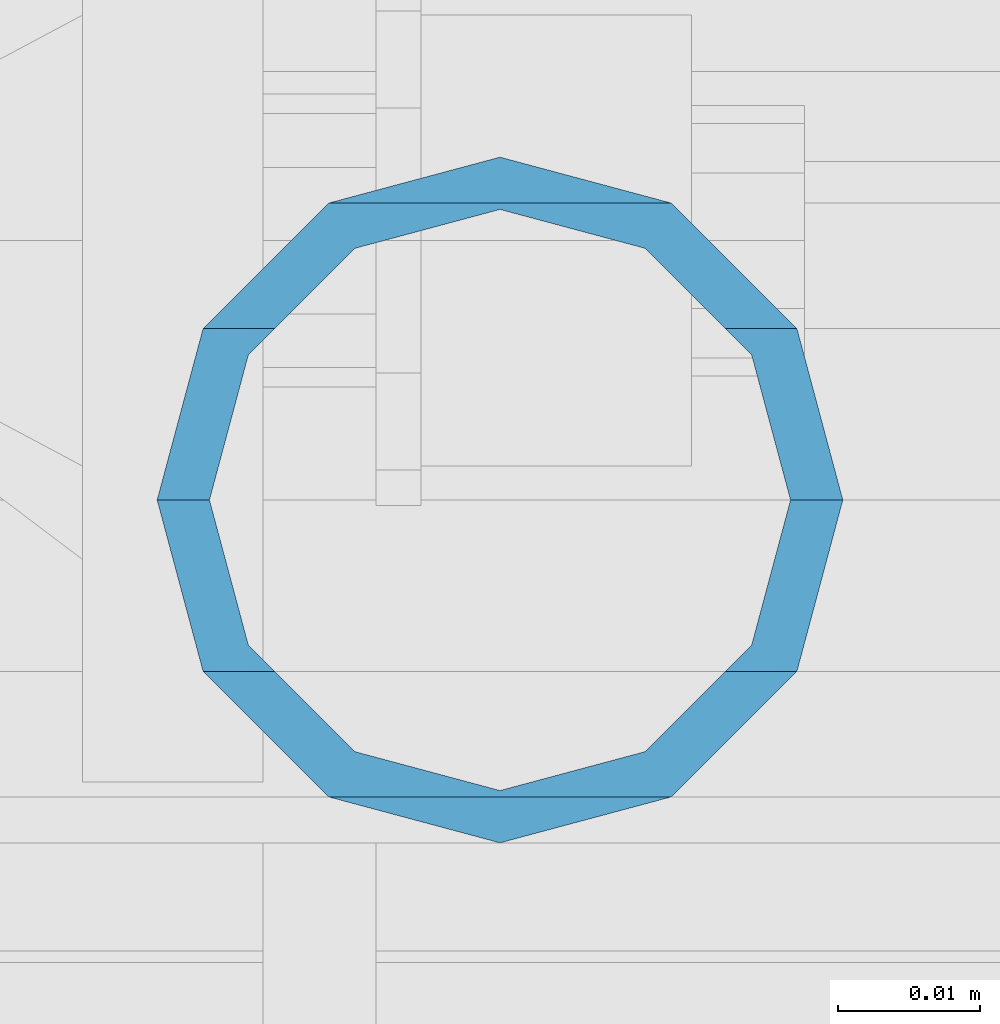
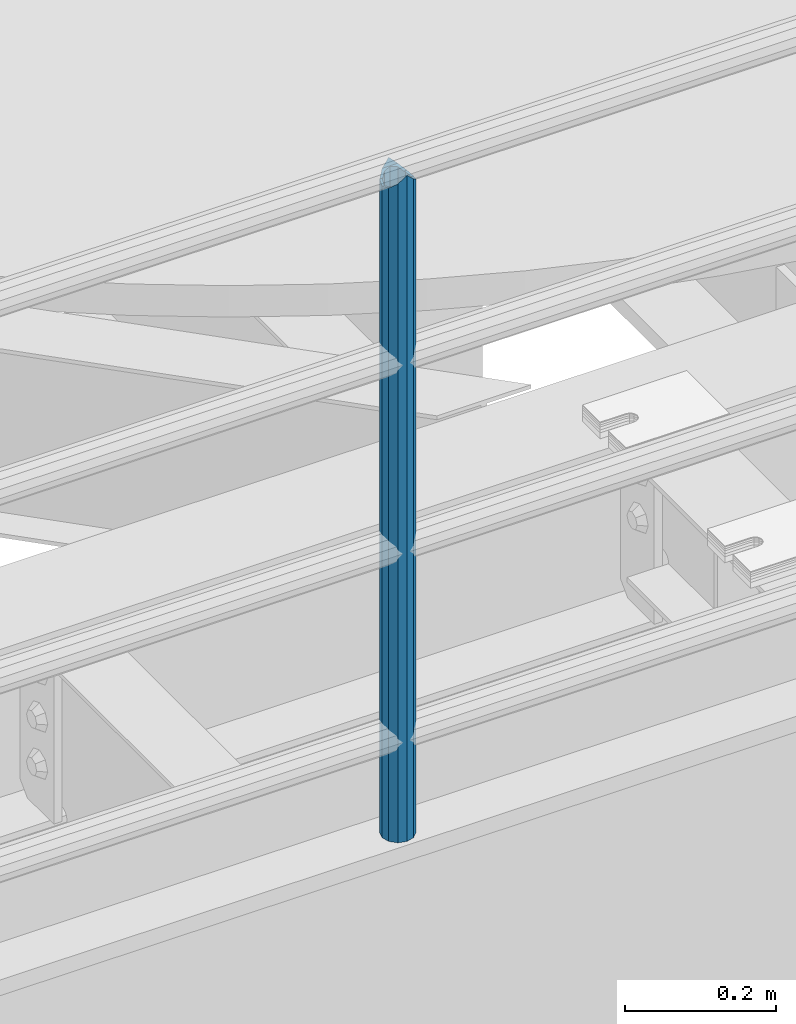
# One storey, part 613 of 1876: 1 column, 1 element without a shape of its own.
"""IFC2X3 building model written with IfcOpenShell, lengths in millimetres."""

from ifc_helpers import new_model, si_unit, frame, origin_with_axes, place, context, subcontext, project, spatial, faceted_brep, material, type_object, element, aggregate, save


model = new_model("IFC2X3")

# Units and contexts
model_context = context("Model", 3, precision=1e-05, world=origin_with_axes())
body_context = subcontext(model_context, "Body", "Model", "MODEL_VIEW")
ifc_project = project(units=[si_unit("LENGTHUNIT", "METRE", prefix="MILLI"), si_unit("AREAUNIT", "SQUARE_METRE"), si_unit("VOLUMEUNIT", "CUBIC_METRE"), si_unit("MASSUNIT", "GRAM", prefix="KILO"), si_unit("TIMEUNIT", "SECOND"), si_unit("PLANEANGLEUNIT", "RADIAN"), si_unit("SOLIDANGLEUNIT", "STERADIAN"), si_unit("THERMODYNAMICTEMPERATUREUNIT", "DEGREE_CELSIUS"), si_unit("LUMINOUSINTENSITYUNIT", "LUMEN")], contexts=[model_context])

# Site, building, storey
site_placement = place(None, origin_with_axes())
site = spatial("IfcSite", under=ifc_project, at=site_placement, CompositionType="ELEMENT")
building_placement = place(site_placement, origin_with_axes())
building = spatial("IfcBuilding", under=site, at=building_placement, Name="Undefined", CompositionType="ELEMENT")
storey_placement = place(building_placement, origin_with_axes())
storey = spatial("IfcBuildingStorey", under=building, at=storey_placement, Name="Undefined", CompositionType="ELEMENT", Elevation=0.0)

# Assembly, column
assembly_placement = place(storey_placement, origin_with_axes())
assembly = element("IfcElementAssembly", 1, at=assembly_placement, inside=storey, Name="RAIL", AssemblyPlace="NOTDEFINED", PredefinedType="RIGID_FRAME")
ifc_material = material()
column_type = type_object("IfcColumnType", Name="PIPE1-1/2SCH40", PredefinedType="NOTDEFINED")
column_placement = place(assembly_placement, frame((2870.19999998823, -4654.55000114554, 17983.2), z_axis=(0.0, 1.0, 0.0), x_axis=(0.0, 0.0, 1.0)))
column = element("IfcColumn", 2, at=column_placement, type_object=column_type, material=ifc_material, Name="POST", ObjectType="PIPE1-1/2SCH40", context=body_context, shape_type="Brep", body=[
    faceted_brep([(1076.325, 0.0, -24.1300000000001), (1064.26, 12.065, -20.8971929933186), (1064.26, -12.0650000000001, -20.8971929933186), (1054.93437856882, 17.7076214311801, 10.2235000000001), (1052.195, 20.4470000000001, 0.0), (1052.195, 24.13, 0.0), (1055.42780700668, 20.8971929933185, 12.0649999999996), (1055.42780700668, 15.8661214311869, 12.0649999999932), (1055.42780700668, 15.8661214311742, -12.065000000006), (1055.42780700668, 20.8971929933185, -12.0649999999996), (1054.93437856882, 17.7076214311801, -10.2235000000001), (1061.07042843786, 10.2235000000001, -17.7076214311801), (1063.80980700668, 0.0, -20.4470000000001), (1061.07042843786, -10.2235000000001, -17.7076214311801), (1055.42780700668, -15.8661214311742, -12.065000000006), (1055.42780700668, -20.8971929933184, -12.0649999999996), (1054.93437856882, -17.7076214311801, -10.2235000000001), (1052.195, -20.4470000000001, 0.0), (1052.195, -24.1300000000001, 0.0), (1054.93437856882, -17.7076214311801, 10.2235000000001), (1055.42780700668, -15.8661214311869, 12.0649999999932), (1055.42780700668, -20.8971929933184, 12.0649999999996), (1076.325, 0.0, 24.1300000000001), (1064.26, -12.0650000000001, 20.8971929933186), (1064.26, 12.065, 20.8971929933186), (1061.07042843787, -10.2235000000001, 17.7076214311801), (1063.80980700669, 0.0, 20.4470000000001), (1061.07042843787, 10.2235000000001, 17.7076214311801), (0.0, -20.8971929933184, -12.0649999999996), (0.0, -12.0650000000001, -20.8971929933186), (-1.45519152283669e-11, 0.0, -24.130000000001), (0.0, 12.0650000000001, -20.8971929933186), (0.0, 20.8971929933184, -12.0649999999996), (0.0, 24.1299999999992, 0.0), (0.0, 20.8971929933184, 12.0649999999996), (0.0, 12.0650000000001, 20.8971929933186), (-1.45519152283669e-11, 0.0, 24.130000000001), (0.0, -20.8971929933184, 12.0649999999996), (0.0, -24.1299999999992, 0.0), (0.0, -12.0650000000001, 20.8971929933186), (0.0, -17.7076214311803, -10.2235000000001), (0.0, -10.2235000000001, -17.7076214311801), (-1.45519152283669e-11, 0.0, -20.4470000000001), (0.0, 10.2235000000001, -17.7076214311801), (0.0, 17.7076214311803, -10.2235000000001), (0.0, 20.4469999999999, 0.0), (0.0, 17.7076214311803, 10.2235000000001), (0.0, 10.2235000000001, 17.7076214311801), (-1.45519152283669e-11, 0.0, 20.4470000000001), (0.0, -10.2235000000001, 17.7076214311801), (0.0, -17.7076214311803, 10.2235000000001), (0.0, -20.4469999999999, 0.0)], [[[0, 1, 2]], [[3, 4, 5, 6, 7]], [[8, 9, 5, 4, 10]], [[2, 1, 9, 8, 11, 12, 13, 14, 15]], [[15, 14, 16, 17, 18]], [[18, 17, 19, 20, 21]], [[22, 23, 24]], [[21, 20, 25, 26, 27, 7, 6, 24, 23]], [[28, 29, 2, 15]], [[29, 30, 0, 2]], [[30, 31, 1, 0]], [[31, 32, 9, 1]], [[32, 33, 5, 9]], [[33, 34, 6, 5]], [[34, 35, 24, 6]], [[35, 36, 22, 24]], [[37, 38, 18, 21]], [[39, 37, 21, 23]], [[36, 39, 23, 22]], [[38, 28, 15, 18]], [[37, 39, 36, 35, 34, 33, 32, 31, 30, 29, 28, 38], [40, 41, 42, 43, 44, 45, 46, 47, 48, 49, 50, 51]], [[49, 48, 26, 25]], [[19, 50, 49, 25, 20]], [[51, 50, 19, 17]], [[40, 51, 17, 16]], [[41, 40, 16, 14, 13]], [[42, 41, 13, 12]], [[43, 42, 12, 11]], [[10, 44, 43, 11, 8]], [[45, 44, 10, 4]], [[46, 45, 4, 3]], [[47, 46, 3, 7, 27]], [[48, 47, 27, 26]]]),
])
aggregate(assembly, [column])

save(model, "model.ifc")
